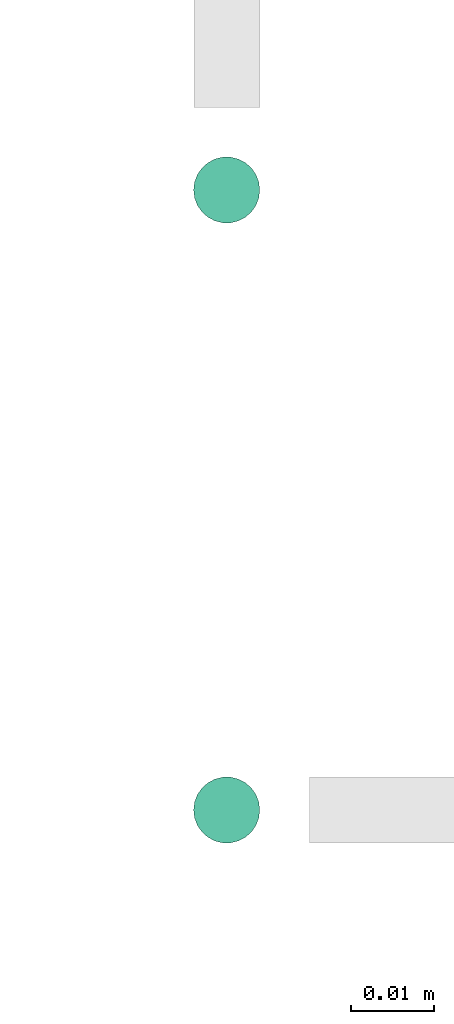
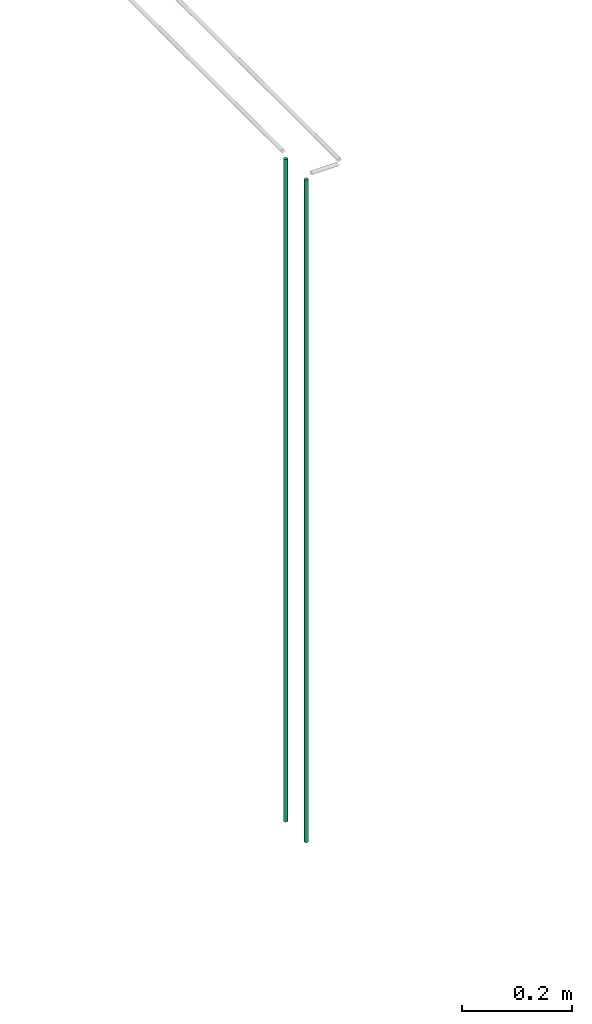
# One storey, part 26 of 89: 3 flow segments.
"""IFC2X3 building model written with IfcOpenShell, lengths in millimetres."""

from ifc_helpers import new_model, entity, si_unit, converted_unit, derived_unit, direction, frame, origin, origin_2d_with_axis, place, context, subcontext, project, spatial, circle, extrude, type_object, element, save


model = new_model("IFC2X3")

# Units and contexts
model_context = context("Model", 3, precision=0.01, world=origin(), true_north=direction((6.12303176911189e-17, 1.0)))
body_context = subcontext(model_context, "Body", "Model", "MODEL_VIEW")
ifc_project = project(units=[si_unit("LENGTHUNIT", "METRE", prefix="MILLI"), si_unit("AREAUNIT", "SQUARE_METRE"), si_unit("VOLUMEUNIT", "CUBIC_METRE"), converted_unit("PLANEANGLEUNIT", "DEGREE", entity("IfcRatioMeasure", 0.0174532925199433), si_unit("PLANEANGLEUNIT", "RADIAN"), dimensions=[0, 0, 0, 0, 0, 0, 0]), si_unit("MASSUNIT", "GRAM", prefix="KILO"), derived_unit("MASSDENSITYUNIT", [(si_unit("MASSUNIT", "GRAM", prefix="KILO"), 1), (si_unit("LENGTHUNIT", "METRE"), -3)]), derived_unit("MOMENTOFINERTIAUNIT", [(si_unit("LENGTHUNIT", "METRE"), 4)]), si_unit("TIMEUNIT", "SECOND"), si_unit("FREQUENCYUNIT", "HERTZ"), si_unit("THERMODYNAMICTEMPERATUREUNIT", "DEGREE_CELSIUS"), derived_unit("THERMALTRANSMITTANCEUNIT", [(si_unit("MASSUNIT", "GRAM", prefix="KILO"), 1), (si_unit("THERMODYNAMICTEMPERATUREUNIT", "KELVIN"), -1), (si_unit("TIMEUNIT", "SECOND"), -3)]), derived_unit("VOLUMETRICFLOWRATEUNIT", [(si_unit("LENGTHUNIT", "METRE"), 3), (si_unit("TIMEUNIT", "SECOND"), -1)]), derived_unit("MASSFLOWRATEUNIT", [(si_unit("MASSUNIT", "GRAM", prefix="KILO"), 1), (si_unit("TIMEUNIT", "SECOND"), -1)]), derived_unit("ROTATIONALFREQUENCYUNIT", [(si_unit("TIMEUNIT", "SECOND"), -1)]), si_unit("ELECTRICCURRENTUNIT", "AMPERE"), si_unit("ELECTRICVOLTAGEUNIT", "VOLT"), si_unit("POWERUNIT", "WATT"), si_unit("FORCEUNIT", "NEWTON", prefix="KILO"), si_unit("ILLUMINANCEUNIT", "LUX"), si_unit("LUMINOUSFLUXUNIT", "LUMEN"), si_unit("LUMINOUSINTENSITYUNIT", "CANDELA"), derived_unit("USERDEFINED", [(si_unit("MASSUNIT", "GRAM", prefix="KILO"), -1), (si_unit("LENGTHUNIT", "METRE"), -2), (si_unit("TIMEUNIT", "SECOND"), 3), (si_unit("LUMINOUSFLUXUNIT", "LUMEN"), 1)]), derived_unit("LINEARVELOCITYUNIT", [(si_unit("LENGTHUNIT", "METRE"), 1), (si_unit("TIMEUNIT", "SECOND"), -1)]), si_unit("PRESSUREUNIT", "PASCAL"), derived_unit("USERDEFINED", [(si_unit("LENGTHUNIT", "METRE"), -2), (si_unit("MASSUNIT", "GRAM", prefix="KILO"), 1), (si_unit("TIMEUNIT", "SECOND"), -2)]), derived_unit("LINEARFORCEUNIT", [(si_unit("MASSUNIT", "GRAM", prefix="KILO"), 1), (si_unit("LENGTHUNIT", "METRE"), 1), (si_unit("TIMEUNIT", "SECOND"), -2), (si_unit("LENGTHUNIT", "METRE"), -1)]), derived_unit("PLANARFORCEUNIT", [(si_unit("MASSUNIT", "GRAM", prefix="KILO"), 1), (si_unit("LENGTHUNIT", "METRE"), 1), (si_unit("TIMEUNIT", "SECOND"), -2), (si_unit("LENGTHUNIT", "METRE"), -2)])], contexts=[model_context])

# Site, building, storey
site_placement = place(None, frame((0.0, -0.00077364408347762, 0.0)))
site = spatial("IfcSite", under=ifc_project, at=site_placement, CompositionType="ELEMENT")
building_placement = place(site_placement, origin())
building = spatial("IfcBuilding", under=site, at=building_placement, CompositionType="ELEMENT")
storey_placement = place(building_placement, frame((0.0, 0.0, 24000.0)))
storey = spatial("IfcBuildingStorey", under=building, at=storey_placement, CompositionType="ELEMENT", Elevation=24000.0)

# Flow segments
pipe_segment_type = type_object("IfcPipeSegmentType", PredefinedType="NOTDEFINED")
flow_segment_1_placement = place(storey_placement, frame((55614.4332266552, 15854.4047204552, 1599.29036474498)))
element("IfcFlowSegment", 1, at=flow_segment_1_placement, inside=storey, type_object=pipe_segment_type, context=body_context, shape_type="SweptSolid", body=[
    extrude(circle(Radius=4.0, at=origin_2d_with_axis()), frame((5.59527223591499, 5.59527223591499, 0.0)), (0.0, 0.0, 1.0), 1465.70963525502),
])
flow_segment_2_placement = place(storey_placement, frame((55614.4332266552, 15854.4047204552, 1599.29036474498)))
element("IfcFlowSegment", 2, at=flow_segment_2_placement, inside=storey, type_object=pipe_segment_type, context=body_context, shape_type="SweptSolid", body=[
    extrude(circle(Radius=4.0, at=origin_2d_with_axis()), frame((5.59527223591499, 5.59527223591499, 0.0)), (0.0, 0.0, 1.0), 1465.70963525503),
])
flow_segment_3_placement = place(storey_placement, frame((55614.4332266557, 15929.4047204551, 1599.29030386191)))
element("IfcFlowSegment", 3, at=flow_segment_3_placement, inside=storey, type_object=pipe_segment_type, context=body_context, shape_type="SweptSolid", body=[
    extrude(circle(Radius=4.0, at=origin_2d_with_axis()), frame((5.59527223545585, 5.59527223591499, 6.08830695000506e-05)), (0.0, 0.0, 1.0), 1465.70963542596),
])

save(model, "model.ifc")
